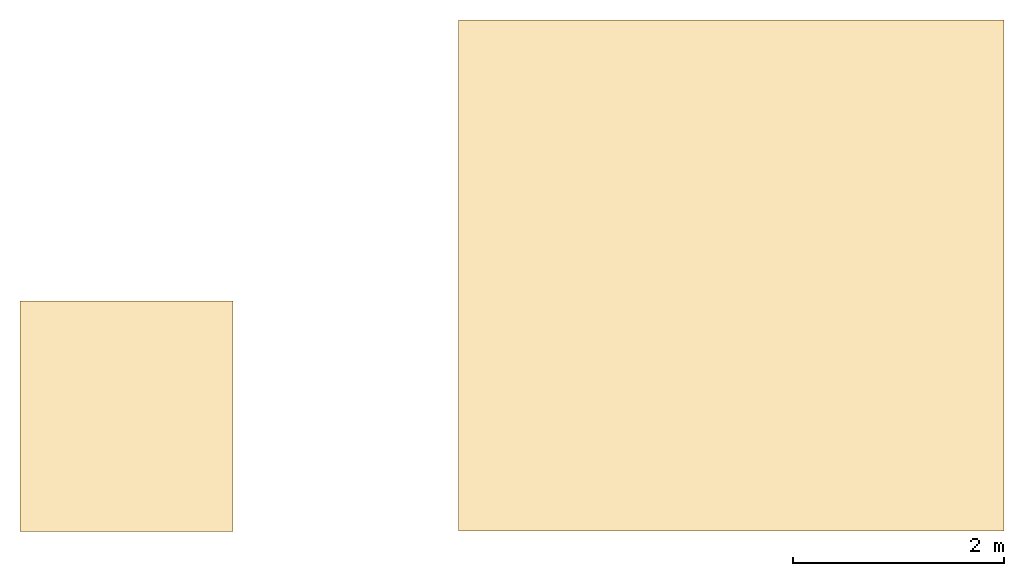
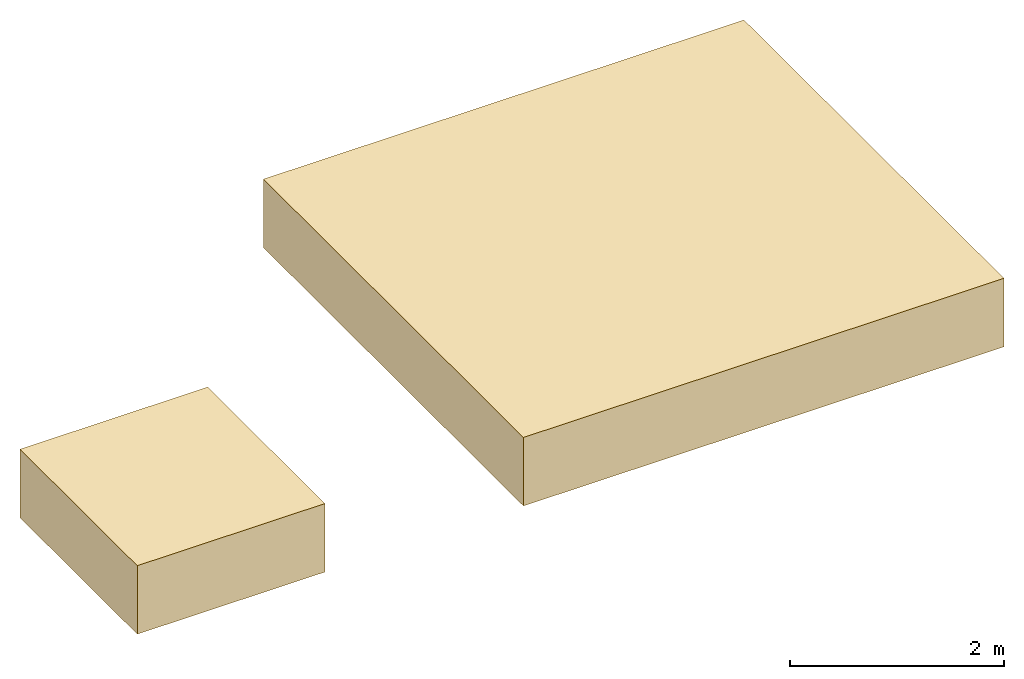
# One storey: 2 coverings.
"""IFC2X3 building model written with IfcOpenShell, lengths in metres."""

from ifc_helpers import new_model, entity, si_unit, converted_unit, derived_unit, direction, frame, frame_2d, origin, place, context, subcontext, project, spatial, rectangle, extrude, material, layer, layer_set, layer_usage, type_object, element, save


model = new_model("IFC2X3")

# Units and contexts
model_context = context("Model", 3, precision=1e-05, world=origin(), true_north=direction((6.123031769111886e-17, 1.0)))
body_context = subcontext(model_context, "Body", "Model", "MODEL_VIEW")
ifc_project = project(units=[si_unit("LENGTHUNIT", "METRE"), si_unit("AREAUNIT", "SQUARE_METRE"), si_unit("VOLUMEUNIT", "CUBIC_METRE"), converted_unit("PLANEANGLEUNIT", "DEGREE", entity("IfcRatioMeasure", 0.017453292519943278), si_unit("PLANEANGLEUNIT", "RADIAN"), dimensions=[0, 0, 0, 0, 0, 0, 0]), si_unit("MASSUNIT", "GRAM", prefix="KILO"), derived_unit("MASSDENSITYUNIT", [(si_unit("MASSUNIT", "GRAM", prefix="KILO"), 1), (si_unit("LENGTHUNIT", "METRE"), -3)]), derived_unit("IONCONCENTRATIONUNIT", [(si_unit("MASSUNIT", "GRAM", prefix="KILO"), 1), (si_unit("LENGTHUNIT", "METRE"), -3)]), derived_unit("MOMENTOFINERTIAUNIT", [(si_unit("LENGTHUNIT", "METRE"), 4)]), si_unit("TIMEUNIT", "SECOND"), si_unit("FREQUENCYUNIT", "HERTZ"), si_unit("THERMODYNAMICTEMPERATUREUNIT", "DEGREE_CELSIUS"), derived_unit("THERMALTRANSMITTANCEUNIT", [(si_unit("MASSUNIT", "GRAM", prefix="KILO"), 1), (si_unit("THERMODYNAMICTEMPERATUREUNIT", "KELVIN"), -1), (si_unit("TIMEUNIT", "SECOND"), -3)]), derived_unit("THERMALCONDUCTANCEUNIT", [(si_unit("MASSUNIT", "GRAM", prefix="KILO"), 1), (si_unit("THERMODYNAMICTEMPERATUREUNIT", "KELVIN"), -1), (si_unit("TIMEUNIT", "SECOND"), -3), (si_unit("LENGTHUNIT", "METRE"), 1)]), derived_unit("VOLUMETRICFLOWRATEUNIT", [(si_unit("LENGTHUNIT", "METRE"), 3), (si_unit("TIMEUNIT", "SECOND"), -1)]), derived_unit("MASSFLOWRATEUNIT", [(si_unit("MASSUNIT", "GRAM", prefix="KILO"), 1), (si_unit("TIMEUNIT", "SECOND"), -1)]), derived_unit("ROTATIONALFREQUENCYUNIT", [(si_unit("TIMEUNIT", "SECOND"), -1)]), si_unit("ELECTRICCURRENTUNIT", "AMPERE"), si_unit("ELECTRICVOLTAGEUNIT", "VOLT"), si_unit("POWERUNIT", "WATT"), si_unit("FORCEUNIT", "NEWTON", prefix="KILO"), si_unit("ILLUMINANCEUNIT", "LUX"), si_unit("LUMINOUSFLUXUNIT", "LUMEN"), si_unit("LUMINOUSINTENSITYUNIT", "CANDELA"), derived_unit("USERDEFINED", [(si_unit("MASSUNIT", "GRAM", prefix="KILO"), -1), (si_unit("LENGTHUNIT", "METRE"), -2), (si_unit("TIMEUNIT", "SECOND"), 3), (si_unit("LUMINOUSFLUXUNIT", "LUMEN"), 1)]), derived_unit("USERDEFINED", [(si_unit("MASSUNIT", "GRAM", prefix="KILO"), 1), (si_unit("TIMEUNIT", "SECOND"), -3), (si_unit("LENGTHUNIT", "METRE"), 3), (si_unit("ELECTRICCURRENTUNIT", "AMPERE"), -2)]), derived_unit("SOUNDPOWERUNIT", [(si_unit("MASSUNIT", "GRAM", prefix="KILO"), 1), (si_unit("TIMEUNIT", "SECOND"), -3), (si_unit("LENGTHUNIT", "METRE"), 2)]), derived_unit("SOUNDPRESSUREUNIT", [(si_unit("MASSUNIT", "GRAM", prefix="KILO"), 1), (si_unit("LENGTHUNIT", "METRE"), -1), (si_unit("TIMEUNIT", "SECOND"), -2)]), derived_unit("LINEARVELOCITYUNIT", [(si_unit("LENGTHUNIT", "METRE"), 1), (si_unit("TIMEUNIT", "SECOND"), -1)]), si_unit("PRESSUREUNIT", "PASCAL"), derived_unit("USERDEFINED", [(si_unit("MASSUNIT", "GRAM", prefix="KILO"), 1), (si_unit("LENGTHUNIT", "METRE"), -2), (si_unit("TIMEUNIT", "SECOND"), -2)]), derived_unit("LINEARFORCEUNIT", [(si_unit("MASSUNIT", "GRAM", prefix="KILO"), 1), (si_unit("TIMEUNIT", "SECOND"), -2)]), derived_unit("PLANARFORCEUNIT", [(si_unit("MASSUNIT", "GRAM", prefix="KILO"), 1), (si_unit("LENGTHUNIT", "METRE"), -1), (si_unit("TIMEUNIT", "SECOND"), -2)]), derived_unit("SPECIFICHEATCAPACITYUNIT", [(si_unit("THERMODYNAMICTEMPERATUREUNIT", "KELVIN"), -1), (si_unit("LENGTHUNIT", "METRE"), 2), (si_unit("TIMEUNIT", "SECOND"), -2)]), derived_unit("HEATINGVALUEUNIT", [(si_unit("LENGTHUNIT", "METRE"), 2), (si_unit("TIMEUNIT", "SECOND"), -2)]), derived_unit("VAPORPERMEABILITYUNIT", [(si_unit("LENGTHUNIT", "METRE"), -1), (si_unit("TIMEUNIT", "SECOND"), 1)]), derived_unit("DYNAMICVISCOSITYUNIT", [(si_unit("MASSUNIT", "GRAM", prefix="KILO"), 1), (si_unit("TIMEUNIT", "SECOND"), -1), (si_unit("LENGTHUNIT", "METRE"), -1)]), derived_unit("THERMALEXPANSIONCOEFFICIENTUNIT", [(si_unit("THERMODYNAMICTEMPERATUREUNIT", "KELVIN"), -1)]), derived_unit("MODULUSOFELASTICITYUNIT", [(si_unit("MASSUNIT", "GRAM", prefix="KILO"), 1), (si_unit("LENGTHUNIT", "METRE"), -1), (si_unit("TIMEUNIT", "SECOND"), -2)]), derived_unit("ISOTHERMALMOISTURECAPACITYUNIT", [(si_unit("LENGTHUNIT", "METRE"), 3), (si_unit("MASSUNIT", "GRAM", prefix="KILO"), -1)]), derived_unit("MOISTUREDIFFUSIVITYUNIT", [(si_unit("TIMEUNIT", "SECOND"), -1), (si_unit("LENGTHUNIT", "METRE"), 2)])], contexts=[model_context])

# Site, building, storey
site_placement = place(None, frame((83.18260837531514, 5.722313863433043, -0.3219974716737357), z_axis=(0.0, 0.0, 1.0), x_axis=(0.31599863684750407, -0.9487596436982969, 0.0)))
site = spatial("IfcSite", under=ifc_project, at=site_placement, CompositionType="ELEMENT")
building_placement = place(site_placement, origin())
building = spatial("IfcBuilding", under=site, at=building_placement, CompositionType="ELEMENT")
storey_placement = place(building_placement, frame((0.0, 0.0, 9.421997471673835)))
storey = spatial("IfcBuildingStorey", under=building, at=storey_placement, Name="Toiture Escalier", CompositionType="ELEMENT", Elevation=9.421997471673835)

# Coverings
ifc_material_1 = material()
ifc_layer_1 = layer(ifc_material_1, 0.1)
ifc_material_2 = material()
ifc_layer_2 = layer(ifc_material_2, 0.08)
ifc_material_3 = material()
ifc_layer_3 = layer(ifc_material_3, 0.5999999999999999)
ifc_layer_set = layer_set([ifc_layer_1, ifc_layer_2, ifc_layer_3], Name="Compound Ceiling:EXT_Toiture_T-ext-03 (FT")
ifc_layer_usage = layer_usage(ifc_layer_set, "AXIS3", "POSITIVE", 0.0)
covering_type = type_object("IfcCoveringType", Name="Compound Ceiling:EXT_Toiture_T-ext-03 (FT", PredefinedType="CEILING")
covering_1_placement = place(storey_placement, origin())
element("IfcCovering", 1, at=covering_1_placement, inside=storey, type_object=covering_type, material=ifc_layer_usage, Name="Compound Ceiling:EXT_Toiture_T-ext-03 (FT", ObjectType="Compound Ceiling:EXT_Toiture_T-ext-03 (FT", PredefinedType="CEILING", context=body_context, shape_type="SweptSolid", body=[
    extrude(rectangle(XDim=4.853002634611004, YDim=5.17790689390621, at=frame_2d((1.7763568394002505e-15, -4.063416270128073e-14), x_axis=(1.0, 0.0))), frame((-21.08309726024587, -51.75130842846788, 0.0), z_axis=(0.0, 0.0, 1.0), x_axis=(-0.9487590375396426, 0.316000456782662, 0.0)), (0.0, 0.0, 1.0), 0.7800000000000002),
])
covering_2_placement = place(storey_placement, origin())
element("IfcCovering", 2, at=covering_2_placement, inside=storey, type_object=covering_type, material=ifc_layer_usage, Name="Compound Ceiling:EXT_Toiture_T-ext-03 (FT", ObjectType="Compound Ceiling:EXT_Toiture_T-ext-03 (FT", PredefinedType="CEILING", context=body_context, shape_type="SweptSolid", body=[
    extrude(rectangle(XDim=2.188470305636577, YDim=2.022000000002389, at=frame_2d((2.7755575615628914e-15, -2.19824158875781e-14), x_axis=(1.0, 0.0))), frame((-21.628845871397992, -57.62171162480985, 0.0), z_axis=(0.0, 0.0, 1.0), x_axis=(-0.9487590375396429, 0.31600045678266137, 0.0)), (0.0, 0.0, 1.0), 0.7800000000000002),
])

save(model, "model.ifc")
